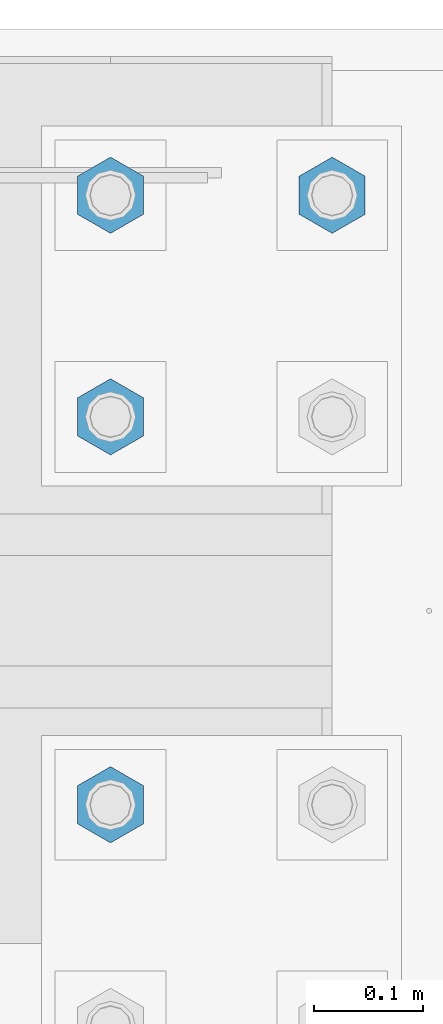
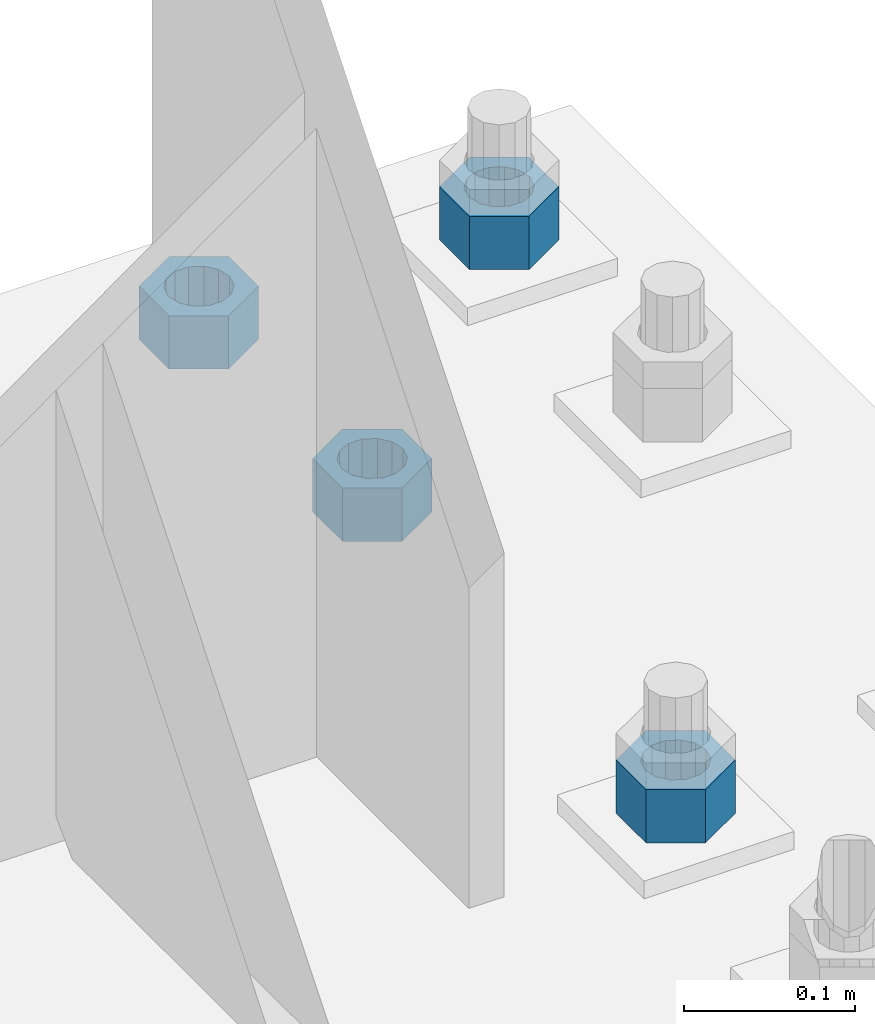
# One storey, part 1736 of 3843: 4 columns, 1 element without a shape of its own.
"""IFC2X3 building model written with IfcOpenShell, lengths in millimetres."""

from ifc_helpers import new_model, si_unit, frame, origin_with_axes, place, context, subcontext, project, spatial, faceted_brep, material, type_object, element, aggregate, save


model = new_model("IFC2X3")

# Units and contexts
model_context = context("Model", 3, precision=1e-05, world=origin_with_axes())
body_context = subcontext(model_context, "Body", "Model", "MODEL_VIEW")
ifc_project = project(units=[si_unit("LENGTHUNIT", "METRE", prefix="MILLI"), si_unit("AREAUNIT", "SQUARE_METRE"), si_unit("VOLUMEUNIT", "CUBIC_METRE"), si_unit("MASSUNIT", "GRAM", prefix="KILO"), si_unit("TIMEUNIT", "SECOND"), si_unit("PLANEANGLEUNIT", "RADIAN"), si_unit("SOLIDANGLEUNIT", "STERADIAN"), si_unit("THERMODYNAMICTEMPERATUREUNIT", "DEGREE_CELSIUS"), si_unit("LUMINOUSINTENSITYUNIT", "LUMEN")], contexts=[model_context])

# Site, building, storey
site_placement = place(None, origin_with_axes())
site = spatial("IfcSite", under=ifc_project, at=site_placement, CompositionType="ELEMENT")
building_placement = place(site_placement, origin_with_axes())
building = spatial("IfcBuilding", under=site, at=building_placement, Name="Undefined", CompositionType="ELEMENT")
storey_placement = place(building_placement, origin_with_axes())
storey = spatial("IfcBuildingStorey", under=building, at=storey_placement, Name="Undefined", CompositionType="ELEMENT", Elevation=0.0)

# Assembly, columns
assembly_placement = place(storey_placement, origin_with_axes())
assembly = element("IfcElementAssembly", 1, at=assembly_placement, inside=storey, Name="TEMPLATE", AssemblyPlace="NOTDEFINED", PredefinedType="RIGID_FRAME")
ifc_material = material(Name="STEEL/A572-50")
column_type = type_object("IfcColumnType", Name="1-1/2_HEAVY_HEX_NUT", PredefinedType="NOTDEFINED")
column_1_placement = place(assembly_placement, frame((86156.8, 104940.1, 29743.4), z_axis=(-1.0, 0.0, 0.0), x_axis=(0.0, 0.0, -1.0)))
column_1 = element("IfcColumn", 2, at=column_1_placement, type_object=column_type, material=ifc_material, Name="NUT", ObjectType="1-1/2_HEAVY_HEX_NUT", context=body_context, shape_type="Brep", body=[
    faceted_brep([(0.0, -34.9199981689453, 0.0), (0.0, -17.4599990844727, -30.25), (38.0999999999985, -17.4599990844727, -30.25), (38.0999999999985, -34.9199981689453, 0.0), (0.0, 17.4599990844727, -30.25), (38.0999999999985, 17.4599990844727, -30.25), (0.0, 34.9199981689453, 0.0), (38.0999999999985, 34.9199981689453, 0.0), (0.0, 17.4599990844727, 30.25), (38.0999999999985, 17.4599990844727, 30.25), (0.0, -17.4599990844727, 30.25), (38.0999999999985, -17.4599990844727, 30.25), (0.0, 0.0, 20.6399993896484), (0.0, 8.9553601105581, 18.5959968835959), (38.0999999999985, 8.9553601105581, 18.5959968835959), (38.0999999999985, 0.0, 20.6399993896484), (0.0, 16.1370013209525, 12.8688291298167), (38.0999999999985, 16.1370013209525, 12.8688291298167), (0.0, 20.1225115123816, 4.59283194104501), (38.0999999999985, 20.1225115123816, 4.59283194104501), (0.0, 20.1225115123816, -4.59283194104501), (38.0999999999985, 20.1225115123816, -4.59283194104501), (0.0, 16.1370013209525, -12.8688291298167), (38.0999999999985, 16.1370013209525, -12.8688291298167), (0.0, 8.9553601105581, -18.5959968835959), (38.0999999999985, 8.9553601105581, -18.5959968835959), (0.0, 0.0, -20.6399993896484), (38.0999999999985, 0.0, -20.6399993896484), (0.0, -8.9553601105581, -18.5959968835959), (38.0999999999985, -8.9553601105581, -18.5959968835959), (0.0, -16.1370013209525, -12.8688291298167), (38.0999999999985, -16.1370013209525, -12.8688291298167), (0.0, -20.1225115123816, -4.59283194104501), (38.0999999999985, -20.1225115123816, -4.59283194104501), (0.0, -20.1225115123816, 4.59283194104501), (38.0999999999985, -20.1225115123816, 4.59283194104501), (0.0, -16.1370013209525, 12.8688291298167), (38.0999999999985, -16.1370013209525, 12.8688291298167), (0.0, -8.9553601105581, 18.5959968835959), (38.0999999999985, -8.9553601105581, 18.5959968835959)], [[[0, 1, 2, 3]], [[1, 4, 5, 2]], [[4, 6, 7, 5]], [[6, 8, 9, 7]], [[8, 10, 11, 9]], [[10, 0, 3, 11]], [[12, 13, 14, 15]], [[13, 16, 17, 14]], [[16, 18, 19, 17]], [[18, 20, 21, 19]], [[20, 22, 23, 21]], [[22, 24, 25, 23]], [[24, 26, 27, 25]], [[26, 28, 29, 27]], [[28, 30, 31, 29]], [[30, 32, 33, 31]], [[32, 34, 35, 33]], [[34, 36, 37, 35]], [[36, 38, 39, 37]], [[38, 12, 15, 39]], [[5, 7, 9, 11, 3, 2], [17, 19, 21, 23, 25, 27, 29, 31, 33, 35, 37, 39, 15, 14]], [[10, 8, 6, 4, 1, 0], [38, 36, 34, 32, 30, 28, 26, 24, 22, 20, 18, 16, 13, 12]]]),
])
column_2_placement = place(assembly_placement, frame((85953.6, 104381.3, 29743.4), z_axis=(1.0, 0.0, 0.0), x_axis=(0.0, 0.0, -1.0)))
column_2 = element("IfcColumn", 3, at=column_2_placement, type_object=column_type, material=ifc_material, Name="NUT", ObjectType="1-1/2_HEAVY_HEX_NUT", context=body_context, shape_type="Brep", body=[
    faceted_brep([(0.0, -34.9199981689453, 0.0), (0.0, -17.4599990844727, -30.25), (38.0999999999985, -17.4599990844727, -30.25), (38.0999999999985, -34.9199981689453, 0.0), (0.0, 17.4599990844727, -30.25), (38.0999999999985, 17.4599990844727, -30.25), (0.0, 34.9199981689453, 0.0), (38.0999999999985, 34.9199981689453, 0.0), (0.0, 17.4599990844727, 30.25), (38.0999999999985, 17.4599990844727, 30.25), (0.0, -17.4599990844727, 30.25), (38.0999999999985, -17.4599990844727, 30.25), (0.0, 0.0, 20.6399993896484), (0.0, 8.9553601105581, 18.5959968835959), (38.0999999999985, 8.9553601105581, 18.5959968835959), (38.0999999999985, 0.0, 20.6399993896484), (0.0, 16.1370013209525, 12.8688291298167), (38.0999999999985, 16.1370013209525, 12.8688291298167), (0.0, 20.1225115123816, 4.59283194104501), (38.0999999999985, 20.1225115123816, 4.59283194104501), (0.0, 20.1225115123816, -4.59283194104501), (38.0999999999985, 20.1225115123816, -4.59283194104501), (0.0, 16.1370013209525, -12.8688291298167), (38.0999999999985, 16.1370013209525, -12.8688291298167), (0.0, 8.9553601105581, -18.5959968835959), (38.0999999999985, 8.9553601105581, -18.5959968835959), (0.0, 0.0, -20.6399993896484), (38.0999999999985, 0.0, -20.6399993896484), (0.0, -8.9553601105581, -18.5959968835959), (38.0999999999985, -8.9553601105581, -18.5959968835959), (0.0, -16.1370013209525, -12.8688291298167), (38.0999999999985, -16.1370013209525, -12.8688291298167), (0.0, -20.1225115123816, -4.59283194104501), (38.0999999999985, -20.1225115123816, -4.59283194104501), (0.0, -20.1225115123816, 4.59283194104501), (38.0999999999985, -20.1225115123816, 4.59283194104501), (0.0, -16.1370013209525, 12.8688291298167), (38.0999999999985, -16.1370013209525, 12.8688291298167), (0.0, -8.9553601105581, 18.5959968835959), (38.0999999999985, -8.9553601105581, 18.5959968835959)], [[[0, 1, 2, 3]], [[1, 4, 5, 2]], [[4, 6, 7, 5]], [[6, 8, 9, 7]], [[8, 10, 11, 9]], [[10, 0, 3, 11]], [[12, 13, 14, 15]], [[13, 16, 17, 14]], [[16, 18, 19, 17]], [[18, 20, 21, 19]], [[20, 22, 23, 21]], [[22, 24, 25, 23]], [[24, 26, 27, 25]], [[26, 28, 29, 27]], [[28, 30, 31, 29]], [[30, 32, 33, 31]], [[32, 34, 35, 33]], [[34, 36, 37, 35]], [[36, 38, 39, 37]], [[38, 12, 15, 39]], [[5, 7, 9, 11, 3, 2], [17, 19, 21, 23, 25, 27, 29, 31, 33, 35, 37, 39, 15, 14]], [[10, 8, 6, 4, 1, 0], [38, 36, 34, 32, 30, 28, 26, 24, 22, 20, 18, 16, 13, 12]]]),
])
column_3_placement = place(assembly_placement, frame((85953.6, 104736.9, 29743.4), z_axis=(-1.0, 0.0, 0.0), x_axis=(0.0, 0.0, -1.0)))
column_3 = element("IfcColumn", 4, at=column_3_placement, type_object=column_type, material=ifc_material, Name="NUT", ObjectType="1-1/2_HEAVY_HEX_NUT", context=body_context, shape_type="Brep", body=[
    faceted_brep([(0.0, -34.9199981689453, 0.0), (0.0, -17.4599990844727, -30.25), (38.0999999999985, -17.4599990844727, -30.25), (38.0999999999985, -34.9199981689453, 0.0), (0.0, 17.4599990844727, -30.25), (38.0999999999985, 17.4599990844727, -30.25), (0.0, 34.9199981689453, 0.0), (38.0999999999985, 34.9199981689453, 0.0), (0.0, 17.4599990844727, 30.25), (38.0999999999985, 17.4599990844727, 30.25), (0.0, -17.4599990844727, 30.25), (38.0999999999985, -17.4599990844727, 30.25), (0.0, 0.0, 20.6399993896484), (0.0, 8.9553601105581, 18.5959968835959), (38.0999999999985, 8.9553601105581, 18.5959968835959), (38.0999999999985, 0.0, 20.6399993896484), (0.0, 16.1370013209525, 12.8688291298167), (38.0999999999985, 16.1370013209525, 12.8688291298167), (0.0, 20.1225115123816, 4.59283194104501), (38.0999999999985, 20.1225115123816, 4.59283194104501), (0.0, 20.1225115123816, -4.59283194104501), (38.0999999999985, 20.1225115123816, -4.59283194104501), (0.0, 16.1370013209525, -12.8688291298167), (38.0999999999985, 16.1370013209525, -12.8688291298167), (0.0, 8.9553601105581, -18.5959968835959), (38.0999999999985, 8.9553601105581, -18.5959968835959), (0.0, 0.0, -20.6399993896484), (38.0999999999985, 0.0, -20.6399993896484), (0.0, -8.9553601105581, -18.5959968835959), (38.0999999999985, -8.9553601105581, -18.5959968835959), (0.0, -16.1370013209525, -12.8688291298167), (38.0999999999985, -16.1370013209525, -12.8688291298167), (0.0, -20.1225115123816, -4.59283194104501), (38.0999999999985, -20.1225115123816, -4.59283194104501), (0.0, -20.1225115123816, 4.59283194104501), (38.0999999999985, -20.1225115123816, 4.59283194104501), (0.0, -16.1370013209525, 12.8688291298167), (38.0999999999985, -16.1370013209525, 12.8688291298167), (0.0, -8.9553601105581, 18.5959968835959), (38.0999999999985, -8.9553601105581, 18.5959968835959)], [[[0, 1, 2, 3]], [[1, 4, 5, 2]], [[4, 6, 7, 5]], [[6, 8, 9, 7]], [[8, 10, 11, 9]], [[10, 0, 3, 11]], [[12, 13, 14, 15]], [[13, 16, 17, 14]], [[16, 18, 19, 17]], [[18, 20, 21, 19]], [[20, 22, 23, 21]], [[22, 24, 25, 23]], [[24, 26, 27, 25]], [[26, 28, 29, 27]], [[28, 30, 31, 29]], [[30, 32, 33, 31]], [[32, 34, 35, 33]], [[34, 36, 37, 35]], [[36, 38, 39, 37]], [[38, 12, 15, 39]], [[5, 7, 9, 11, 3, 2], [17, 19, 21, 23, 25, 27, 29, 31, 33, 35, 37, 39, 15, 14]], [[10, 8, 6, 4, 1, 0], [38, 36, 34, 32, 30, 28, 26, 24, 22, 20, 18, 16, 13, 12]]]),
])
column_4_placement = place(assembly_placement, frame((85953.6, 104940.1, 29743.4), z_axis=(-1.0, 0.0, 0.0), x_axis=(0.0, 0.0, -1.0)))
column_4 = element("IfcColumn", 5, at=column_4_placement, type_object=column_type, material=ifc_material, Name="NUT", ObjectType="1-1/2_HEAVY_HEX_NUT", context=body_context, shape_type="Brep", body=[
    faceted_brep([(0.0, -34.9199981689453, 0.0), (0.0, -17.4599990844727, -30.25), (38.0999999999985, -17.4599990844727, -30.25), (38.0999999999985, -34.9199981689453, 0.0), (0.0, 17.4599990844727, -30.25), (38.0999999999985, 17.4599990844727, -30.25), (0.0, 34.9199981689453, 0.0), (38.0999999999985, 34.9199981689453, 0.0), (0.0, 17.4599990844727, 30.25), (38.0999999999985, 17.4599990844727, 30.25), (0.0, -17.4599990844727, 30.25), (38.0999999999985, -17.4599990844727, 30.25), (0.0, 0.0, 20.6399993896484), (0.0, 8.9553601105581, 18.5959968835959), (38.0999999999985, 8.9553601105581, 18.5959968835959), (38.0999999999985, 0.0, 20.6399993896484), (0.0, 16.1370013209525, 12.8688291298167), (38.0999999999985, 16.1370013209525, 12.8688291298167), (0.0, 20.1225115123816, 4.59283194104501), (38.0999999999985, 20.1225115123816, 4.59283194104501), (0.0, 20.1225115123816, -4.59283194104501), (38.0999999999985, 20.1225115123816, -4.59283194104501), (0.0, 16.1370013209525, -12.8688291298167), (38.0999999999985, 16.1370013209525, -12.8688291298167), (0.0, 8.9553601105581, -18.5959968835959), (38.0999999999985, 8.9553601105581, -18.5959968835959), (0.0, 0.0, -20.6399993896484), (38.0999999999985, 0.0, -20.6399993896484), (0.0, -8.9553601105581, -18.5959968835959), (38.0999999999985, -8.9553601105581, -18.5959968835959), (0.0, -16.1370013209525, -12.8688291298167), (38.0999999999985, -16.1370013209525, -12.8688291298167), (0.0, -20.1225115123816, -4.59283194104501), (38.0999999999985, -20.1225115123816, -4.59283194104501), (0.0, -20.1225115123816, 4.59283194104501), (38.0999999999985, -20.1225115123816, 4.59283194104501), (0.0, -16.1370013209525, 12.8688291298167), (38.0999999999985, -16.1370013209525, 12.8688291298167), (0.0, -8.9553601105581, 18.5959968835959), (38.0999999999985, -8.9553601105581, 18.5959968835959)], [[[0, 1, 2, 3]], [[1, 4, 5, 2]], [[4, 6, 7, 5]], [[6, 8, 9, 7]], [[8, 10, 11, 9]], [[10, 0, 3, 11]], [[12, 13, 14, 15]], [[13, 16, 17, 14]], [[16, 18, 19, 17]], [[18, 20, 21, 19]], [[20, 22, 23, 21]], [[22, 24, 25, 23]], [[24, 26, 27, 25]], [[26, 28, 29, 27]], [[28, 30, 31, 29]], [[30, 32, 33, 31]], [[32, 34, 35, 33]], [[34, 36, 37, 35]], [[36, 38, 39, 37]], [[38, 12, 15, 39]], [[5, 7, 9, 11, 3, 2], [17, 19, 21, 23, 25, 27, 29, 31, 33, 35, 37, 39, 15, 14]], [[10, 8, 6, 4, 1, 0], [38, 36, 34, 32, 30, 28, 26, 24, 22, 20, 18, 16, 13, 12]]]),
])
aggregate(assembly, [column_1, column_2, column_3, column_4])

save(model, "model.ifc")
